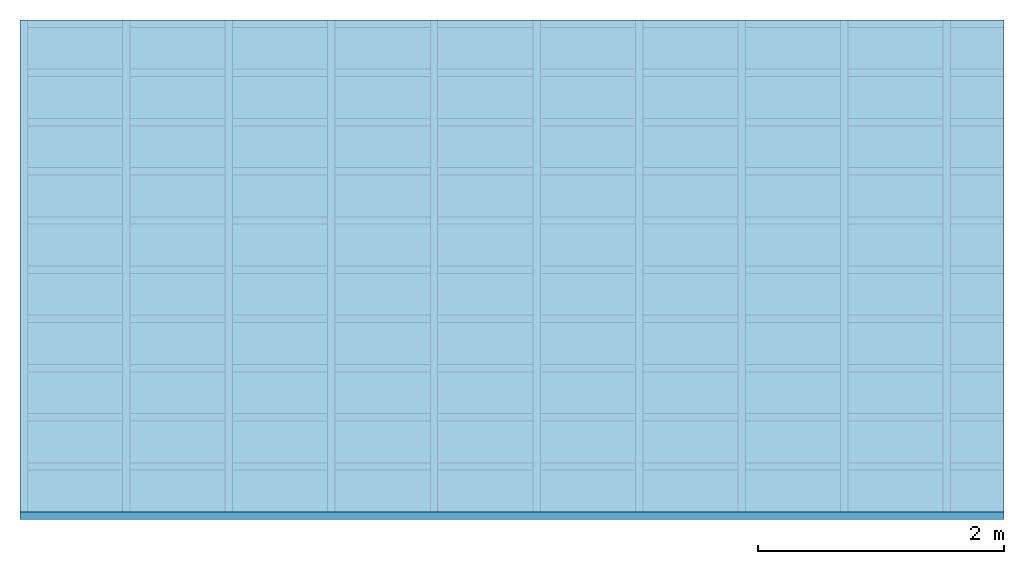
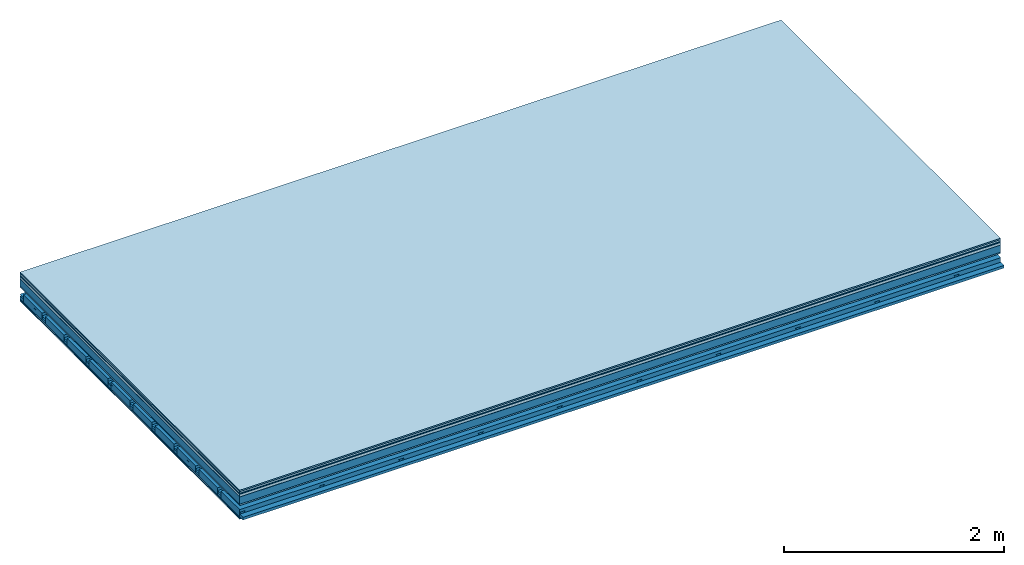
# One storey: 9 plates, 4 members, 1 element without a shape of its own.
"""IFC4 building model written with IfcOpenShell, lengths in metres."""

from ifc_helpers import new_model, si_unit, derived_unit, direction, frame, frame_2d, origin, origin_with_axes, place, context, project, spatial, polyline, rectangle, outline, extrude, material, layer, layer_set, type_object, element, aggregate, save


model = new_model("IFC4")

# Units and contexts
plan_context = context("Plan", 3, precision=1e-05, world=origin(), true_north=direction((0.0, 1.0)))
model_context = context("Model", 3, precision=1e-05, world=origin(), true_north=direction((0.0, 1.0)))
ifc_project = project(units=[si_unit("LENGTHUNIT", "METRE"), derived_unit("SOUNDPRESSUREUNIT", [(si_unit("PRESSUREUNIT", "PASCAL", prefix="MICRO"), 0)]), si_unit("ENERGYUNIT", "JOULE", prefix="MEGA"), si_unit("MASSUNIT", "GRAM", prefix="KILO"), derived_unit("THERMALTRANSMITTANCEUNIT", [(si_unit("POWERUNIT", "WATT"), 1), (si_unit("AREAUNIT", "SQUARE_METRE"), -1), (si_unit("THERMODYNAMICTEMPERATUREUNIT", "KELVIN"), -1)]), derived_unit("AREADENSITYUNIT", [(si_unit("MASSUNIT", "GRAM", prefix="KILO"), 1), (si_unit("AREAUNIT", "SQUARE_METRE"), -1)]), derived_unit("USERDEFINED", [(si_unit("ENERGYUNIT", "JOULE", prefix="MEGA"), 1), (si_unit("AREAUNIT", "SQUARE_METRE"), -1)])], contexts=[plan_context, model_context])

# Site, building, storey
site = spatial("IfcSite", under=ifc_project)
building_placement = place(None, origin())
building = spatial("IfcBuilding", under=site, at=building_placement)
storey_placement = place(building_placement, origin())
storey = spatial("IfcBuildingStorey", under=building, at=storey_placement)

# Slab, members, plates
ifc_material_1 = material(Category="11.013")
ifc_layer_1 = layer(ifc_material_1, 0.015, Name="Flooring")
ifc_material_2 = material(Category="03.007")
ifc_layer_2 = layer(ifc_material_2, 0.02, Name="On-material")
ifc_material_3 = material(Name="Wood fiber generic product", Category="10.009")
ifc_layer_3 = layer(ifc_material_3, 0.01, Name="Impact sound insulation")
ifc_material_4 = material(Name="with broken")
ifc_layer_4 = layer(ifc_material_4, 0.03, Name="on Supporting structure")
ifc_material_5 = material(Name="protection", Category="09.007")
ifc_layer_5 = layer(ifc_material_5, 0.0005, Name="Sub-floor")
ifc_material_6 = material(Name="no composite action")
ifc_layer_6 = layer(ifc_material_6, 0.0, Name="Bond")
ifc_layer_7 = layer(None, 0.08, Name="Supporting structure")
ifc_material_7 = material(Name="of the art")
ifc_layer_8 = layer(ifc_material_7, 0.0, Name="Bond")
ifc_layer_9 = layer(ifc_material_2, 0.015, Name="Lower layer 1")
ifc_layer_10 = layer(None, 0.095, Name="Coupling")
ifc_layer_11 = layer(None, 0.03, Name="Battens / profiles")
ifc_material_8 = material(Name="Plasterboard type A", Category="03.008")
ifc_layer_12 = layer(ifc_material_8, 0.0125, Name="Ceiling covering 1st layer")
ifc_layer_13 = layer(ifc_material_8, 0.0125, Name="Ceiling covering layer 2")
ifc_material_9 = material(Category="04.001")
ifc_layer_14 = layer(ifc_material_9, 0.003, Name="Surface / treatment")
ifc_layer_set = layer_set([ifc_layer_1, ifc_layer_2, ifc_layer_3, ifc_layer_4, ifc_layer_5, ifc_layer_6, ifc_layer_7, ifc_layer_8, ifc_layer_9, ifc_layer_10, ifc_layer_11, ifc_layer_12, ifc_layer_13, ifc_layer_14])
slab_type = type_object("IfcSlabType", Name="A2121", PredefinedType="NOTDEFINED", material=ifc_layer_set)
slab_placement = place(None, frame((0.0, 0.0, 0.0), z_axis=(0.0, 0.0, -1.0), x_axis=(1.0, 0.0, 0.0)))
slab = element("IfcSlab", 1, at=slab_placement, inside=storey, type_object=slab_type, material=ifc_layer_set, Name="Slab #1")
ifc_material_10 = material(Name="Solid timber panel")
member_1_placement = place(slab_placement, origin())
member_1 = element("IfcMember", 2, at=member_1_placement, material=ifc_material_10, Name="Supporting structure", context=plan_context, shape_type="SweptSolid", body=[
    extrude(rectangle(XDim=1.0, YDim=0.08, at=frame_2d((0.5, 0.04), x_axis=(1.0, 0.0))), frame((0.0, 4.0, 0.0755), z_axis=(0.0, -1.0, 0.0), x_axis=(1.0, 0.0, 0.0)), (0.0, 0.0, 1.0), 4.0),
    extrude(rectangle(XDim=1.0, YDim=0.08, at=frame_2d((0.5, 0.04), x_axis=(1.0, 0.0))), frame((1.0, 4.0, 0.0755), z_axis=(0.0, -1.0, 0.0), x_axis=(1.0, 0.0, 0.0)), (0.0, 0.0, 1.0), 4.0),
    extrude(rectangle(XDim=1.0, YDim=0.08, at=frame_2d((0.5, 0.04), x_axis=(1.0, 0.0))), frame((2.0, 4.0, 0.0755), z_axis=(0.0, -1.0, 0.0), x_axis=(1.0, 0.0, 0.0)), (0.0, 0.0, 1.0), 4.0),
    extrude(rectangle(XDim=1.0, YDim=0.08, at=frame_2d((0.5, 0.04), x_axis=(1.0, 0.0))), frame((3.0, 4.0, 0.0755), z_axis=(0.0, -1.0, 0.0), x_axis=(1.0, 0.0, 0.0)), (0.0, 0.0, 1.0), 4.0),
    extrude(rectangle(XDim=1.0, YDim=0.08, at=frame_2d((0.5, 0.04), x_axis=(1.0, 0.0))), frame((4.0, 4.0, 0.0755), z_axis=(0.0, -1.0, 0.0), x_axis=(1.0, 0.0, 0.0)), (0.0, 0.0, 1.0), 4.0),
    extrude(rectangle(XDim=1.0, YDim=0.08, at=frame_2d((0.5, 0.04), x_axis=(1.0, 0.0))), frame((5.0, 4.0, 0.0755), z_axis=(0.0, -1.0, 0.0), x_axis=(1.0, 0.0, 0.0)), (0.0, 0.0, 1.0), 4.0),
    extrude(rectangle(XDim=1.0, YDim=0.08, at=frame_2d((0.5, 0.04), x_axis=(1.0, 0.0))), frame((6.0, 4.0, 0.0755), z_axis=(0.0, -1.0, 0.0), x_axis=(1.0, 0.0, 0.0)), (0.0, 0.0, 1.0), 4.0),
    extrude(rectangle(XDim=1.0, YDim=0.08, at=frame_2d((0.5, 0.04), x_axis=(1.0, 0.0))), frame((7.0, 4.0, 0.0755), z_axis=(0.0, -1.0, 0.0), x_axis=(1.0, 0.0, 0.0)), (0.0, 0.0, 1.0), 4.0),
])
ifc_material_11 = material()
member_2_placement = place(slab_placement, origin())
member_2 = element("IfcMember", 3, at=member_2_placement, material=ifc_material_11, Name="Coupling", context=plan_context, shape_type="SweptSolid", body=[
    extrude(outline(polyline([(0.0, 0.0), (0.06, 0.0), (0.04, 0.02), (0.02, 0.02), (0.0, 0.0)])), frame((0.0, 4.0, 0.2455), z_axis=(0.0, -1.0, 0.0), x_axis=(1.0, 0.0, 0.0)), (0.0, 0.0, 1.0), 4.0),
    extrude(outline(polyline([(0.0, 0.0), (0.06, 0.0), (0.04, 0.02), (0.02, 0.02), (0.0, 0.0)])), frame((0.834, 4.0, 0.2455), z_axis=(0.0, -1.0, 0.0), x_axis=(1.0, 0.0, 0.0)), (0.0, 0.0, 1.0), 4.0),
    extrude(outline(polyline([(0.0, 0.0), (0.06, 0.0), (0.04, 0.02), (0.02, 0.02), (0.0, 0.0)])), frame((1.668, 4.0, 0.2455), z_axis=(0.0, -1.0, 0.0), x_axis=(1.0, 0.0, 0.0)), (0.0, 0.0, 1.0), 4.0),
    extrude(outline(polyline([(0.0, 0.0), (0.06, 0.0), (0.04, 0.02), (0.02, 0.02), (0.0, 0.0)])), frame((2.502, 4.0, 0.2455), z_axis=(0.0, -1.0, 0.0), x_axis=(1.0, 0.0, 0.0)), (0.0, 0.0, 1.0), 4.0),
    extrude(outline(polyline([(0.0, 0.0), (0.06, 0.0), (0.04, 0.02), (0.02, 0.02), (0.0, 0.0)])), frame((3.336, 4.0, 0.2455), z_axis=(0.0, -1.0, 0.0), x_axis=(1.0, 0.0, 0.0)), (0.0, 0.0, 1.0), 4.0),
    extrude(outline(polyline([(0.0, 0.0), (0.06, 0.0), (0.04, 0.02), (0.02, 0.02), (0.0, 0.0)])), frame((4.17, 4.0, 0.2455), z_axis=(0.0, -1.0, 0.0), x_axis=(1.0, 0.0, 0.0)), (0.0, 0.0, 1.0), 4.0),
    extrude(outline(polyline([(0.0, 0.0), (0.06, 0.0), (0.04, 0.02), (0.02, 0.02), (0.0, 0.0)])), frame((5.004, 4.0, 0.2455), z_axis=(0.0, -1.0, 0.0), x_axis=(1.0, 0.0, 0.0)), (0.0, 0.0, 1.0), 4.0),
    extrude(outline(polyline([(0.0, 0.0), (0.06, 0.0), (0.04, 0.02), (0.02, 0.02), (0.0, 0.0)])), frame((5.838, 4.0, 0.2455), z_axis=(0.0, -1.0, 0.0), x_axis=(1.0, 0.0, 0.0)), (0.0, 0.0, 1.0), 4.0),
    extrude(outline(polyline([(0.0, 0.0), (0.06, 0.0), (0.04, 0.02), (0.02, 0.02), (0.0, 0.0)])), frame((6.672, 4.0, 0.2455), z_axis=(0.0, -1.0, 0.0), x_axis=(1.0, 0.0, 0.0)), (0.0, 0.0, 1.0), 4.0),
    extrude(outline(polyline([(0.0, 0.0), (0.06, 0.0), (0.04, 0.02), (0.02, 0.02), (0.0, 0.0)])), frame((7.506, 4.0, 0.2455), z_axis=(0.0, -1.0, 0.0), x_axis=(1.0, 0.0, 0.0)), (0.0, 0.0, 1.0), 4.0),
])
member_3_placement = place(slab_placement, origin())
member_3 = element("IfcMember", 4, at=member_3_placement, material=ifc_material_11, Name="Battens / profiles", context=plan_context, shape_type="SweptSolid", body=[
    extrude(rectangle(XDim=0.06, YDim=0.03, at=frame_2d((0.03, 0.015), x_axis=(1.0, 0.0))), frame((0.0, 0.0, 0.2655), z_axis=(1.0, 0.0, 0.0), x_axis=(0.0, 1.0, 0.0)), (0.0, 0.0, 1.0), 8.0),
    extrude(rectangle(XDim=0.06, YDim=0.03, at=frame_2d((0.03, 0.015), x_axis=(1.0, 0.0))), frame((0.0, 0.4, 0.2655), z_axis=(1.0, 0.0, 0.0), x_axis=(0.0, 1.0, 0.0)), (0.0, 0.0, 1.0), 8.0),
    extrude(rectangle(XDim=0.06, YDim=0.03, at=frame_2d((0.03, 0.015), x_axis=(1.0, 0.0))), frame((0.0, 0.8, 0.2655), z_axis=(1.0, 0.0, 0.0), x_axis=(0.0, 1.0, 0.0)), (0.0, 0.0, 1.0), 8.0),
    extrude(rectangle(XDim=0.06, YDim=0.03, at=frame_2d((0.03, 0.015), x_axis=(1.0, 0.0))), frame((0.0, 1.2, 0.2655), z_axis=(1.0, 0.0, 0.0), x_axis=(0.0, 1.0, 0.0)), (0.0, 0.0, 1.0), 8.0),
    extrude(rectangle(XDim=0.06, YDim=0.03, at=frame_2d((0.03, 0.015), x_axis=(1.0, 0.0))), frame((0.0, 1.6, 0.2655), z_axis=(1.0, 0.0, 0.0), x_axis=(0.0, 1.0, 0.0)), (0.0, 0.0, 1.0), 8.0),
    extrude(rectangle(XDim=0.06, YDim=0.03, at=frame_2d((0.03, 0.015), x_axis=(1.0, 0.0))), frame((0.0, 2.0, 0.2655), z_axis=(1.0, 0.0, 0.0), x_axis=(0.0, 1.0, 0.0)), (0.0, 0.0, 1.0), 8.0),
    extrude(rectangle(XDim=0.06, YDim=0.03, at=frame_2d((0.03, 0.015), x_axis=(1.0, 0.0))), frame((0.0, 2.4, 0.2655), z_axis=(1.0, 0.0, 0.0), x_axis=(0.0, 1.0, 0.0)), (0.0, 0.0, 1.0), 8.0),
    extrude(rectangle(XDim=0.06, YDim=0.03, at=frame_2d((0.03, 0.015), x_axis=(1.0, 0.0))), frame((0.0, 2.8, 0.2655), z_axis=(1.0, 0.0, 0.0), x_axis=(0.0, 1.0, 0.0)), (0.0, 0.0, 1.0), 8.0),
    extrude(rectangle(XDim=0.06, YDim=0.03, at=frame_2d((0.03, 0.015), x_axis=(1.0, 0.0))), frame((0.0, 3.2, 0.2655), z_axis=(1.0, 0.0, 0.0), x_axis=(0.0, 1.0, 0.0)), (0.0, 0.0, 1.0), 8.0),
    extrude(rectangle(XDim=0.06, YDim=0.03, at=frame_2d((0.03, 0.015), x_axis=(1.0, 0.0))), frame((0.0, 3.6, 0.2655), z_axis=(1.0, 0.0, 0.0), x_axis=(0.0, 1.0, 0.0)), (0.0, 0.0, 1.0), 8.0),
    extrude(rectangle(XDim=0.06, YDim=0.03, at=frame_2d((0.03, 0.015), x_axis=(1.0, 0.0))), frame((0.0, 4.0, 0.2655), z_axis=(1.0, 0.0, 0.0), x_axis=(0.0, 1.0, 0.0)), (0.0, 0.0, 1.0), 8.0),
])
ifc_material_12 = material()
member_4_placement = place(slab_placement, origin())
member_4 = element("IfcMember", 5, at=member_4_placement, material=ifc_material_12, Name="Cavity", context=plan_context, shape_type="SweptSolid", body=[
    extrude(rectangle(XDim=0.34, YDim=0.08, at=frame_2d((0.17, 0.04), x_axis=(1.0, 0.0))), frame((0.0, 0.06, 0.2155), z_axis=(1.0, 0.0, 0.0), x_axis=(0.0, 1.0, 0.0)), (0.0, 0.0, 1.0), 8.0),
    extrude(rectangle(XDim=0.34, YDim=0.08, at=frame_2d((0.17, 0.04), x_axis=(1.0, 0.0))), frame((0.0, 0.46, 0.2155), z_axis=(1.0, 0.0, 0.0), x_axis=(0.0, 1.0, 0.0)), (0.0, 0.0, 1.0), 8.0),
    extrude(rectangle(XDim=0.34, YDim=0.08, at=frame_2d((0.17, 0.04), x_axis=(1.0, 0.0))), frame((0.0, 0.86, 0.2155), z_axis=(1.0, 0.0, 0.0), x_axis=(0.0, 1.0, 0.0)), (0.0, 0.0, 1.0), 8.0),
    extrude(rectangle(XDim=0.34, YDim=0.08, at=frame_2d((0.17, 0.04), x_axis=(1.0, 0.0))), frame((0.0, 1.26, 0.2155), z_axis=(1.0, 0.0, 0.0), x_axis=(0.0, 1.0, 0.0)), (0.0, 0.0, 1.0), 8.0),
    extrude(rectangle(XDim=0.34, YDim=0.08, at=frame_2d((0.17, 0.04), x_axis=(1.0, 0.0))), frame((0.0, 1.66, 0.2155), z_axis=(1.0, 0.0, 0.0), x_axis=(0.0, 1.0, 0.0)), (0.0, 0.0, 1.0), 8.0),
    extrude(rectangle(XDim=0.34, YDim=0.08, at=frame_2d((0.17, 0.04), x_axis=(1.0, 0.0))), frame((0.0, 2.06, 0.2155), z_axis=(1.0, 0.0, 0.0), x_axis=(0.0, 1.0, 0.0)), (0.0, 0.0, 1.0), 8.0),
    extrude(rectangle(XDim=0.34, YDim=0.08, at=frame_2d((0.17, 0.04), x_axis=(1.0, 0.0))), frame((0.0, 2.46, 0.2155), z_axis=(1.0, 0.0, 0.0), x_axis=(0.0, 1.0, 0.0)), (0.0, 0.0, 1.0), 8.0),
    extrude(rectangle(XDim=0.34, YDim=0.08, at=frame_2d((0.17, 0.04), x_axis=(1.0, 0.0))), frame((0.0, 2.86, 0.2155), z_axis=(1.0, 0.0, 0.0), x_axis=(0.0, 1.0, 0.0)), (0.0, 0.0, 1.0), 8.0),
    extrude(rectangle(XDim=0.34, YDim=0.08, at=frame_2d((0.17, 0.04), x_axis=(1.0, 0.0))), frame((0.0, 3.26, 0.2155), z_axis=(1.0, 0.0, 0.0), x_axis=(0.0, 1.0, 0.0)), (0.0, 0.0, 1.0), 8.0),
    extrude(rectangle(XDim=0.34, YDim=0.08, at=frame_2d((0.17, 0.04), x_axis=(1.0, 0.0))), frame((0.0, 3.66, 0.2155), z_axis=(1.0, 0.0, 0.0), x_axis=(0.0, 1.0, 0.0)), (0.0, 0.0, 1.0), 8.0),
])
plate_1_placement = place(slab_placement, origin())
plate_1 = element("IfcPlate", 6, at=plate_1_placement, material=ifc_material_1, Name="Flooring", context=plan_context, shape_type="SweptSolid", body=[
    extrude(rectangle(XDim=8.0, YDim=4.0, at=frame_2d((4.0, 2.0), x_axis=(1.0, 0.0))), origin_with_axes(), (0.0, 0.0, 1.0), 0.015),
])
plate_2_placement = place(slab_placement, origin())
plate_2 = element("IfcPlate", 7, at=plate_2_placement, material=ifc_material_2, Name="On-material", context=plan_context, shape_type="SweptSolid", body=[
    extrude(rectangle(XDim=8.0, YDim=4.0, at=frame_2d((4.0, 2.0), x_axis=(1.0, 0.0))), frame((0.0, 0.0, 0.015), z_axis=(0.0, 0.0, 1.0), x_axis=(1.0, 0.0, 0.0)), (0.0, 0.0, 1.0), 0.02),
])
plate_3_placement = place(slab_placement, origin())
plate_3 = element("IfcPlate", 8, at=plate_3_placement, material=ifc_material_3, Name="Impact sound insulation", context=plan_context, shape_type="SweptSolid", body=[
    extrude(rectangle(XDim=8.0, YDim=4.0, at=frame_2d((4.0, 2.0), x_axis=(1.0, 0.0))), frame((0.0, 0.0, 0.035), z_axis=(0.0, 0.0, 1.0), x_axis=(1.0, 0.0, 0.0)), (0.0, 0.0, 1.0), 0.01),
])
plate_4_placement = place(slab_placement, origin())
plate_4 = element("IfcPlate", 9, at=plate_4_placement, material=ifc_material_4, Name="on Supporting structure", context=plan_context, shape_type="SweptSolid", body=[
    extrude(rectangle(XDim=8.0, YDim=4.0, at=frame_2d((4.0, 2.0), x_axis=(1.0, 0.0))), frame((0.0, 0.0, 0.045), z_axis=(0.0, 0.0, 1.0), x_axis=(1.0, 0.0, 0.0)), (0.0, 0.0, 1.0), 0.03),
])
plate_5_placement = place(slab_placement, origin())
plate_5 = element("IfcPlate", 10, at=plate_5_placement, material=ifc_material_5, Name="Sub-floor", context=plan_context, shape_type="SweptSolid", body=[
    extrude(rectangle(XDim=8.0, YDim=4.0, at=frame_2d((4.0, 2.0), x_axis=(1.0, 0.0))), frame((0.0, 0.0, 0.075), z_axis=(0.0, 0.0, 1.0), x_axis=(1.0, 0.0, 0.0)), (0.0, 0.0, 1.0), 0.0005),
])
plate_6_placement = place(slab_placement, origin())
plate_6 = element("IfcPlate", 11, at=plate_6_placement, material=ifc_material_2, Name="Lower layer 1", context=plan_context, shape_type="SweptSolid", body=[
    extrude(rectangle(XDim=8.0, YDim=4.0, at=frame_2d((4.0, 2.0), x_axis=(1.0, 0.0))), frame((0.0, 0.0, 0.1555), z_axis=(0.0, 0.0, 1.0), x_axis=(1.0, 0.0, 0.0)), (0.0, 0.0, 1.0), 0.015),
])
plate_7_placement = place(slab_placement, origin())
plate_7 = element("IfcPlate", 12, at=plate_7_placement, material=ifc_material_8, Name="Ceiling covering 1st layer", context=plan_context, shape_type="SweptSolid", body=[
    extrude(rectangle(XDim=8.0, YDim=4.0, at=frame_2d((4.0, 2.0), x_axis=(1.0, 0.0))), frame((0.0, 0.0, 0.2955), z_axis=(0.0, 0.0, 1.0), x_axis=(1.0, 0.0, 0.0)), (0.0, 0.0, 1.0), 0.0125),
])
plate_8_placement = place(slab_placement, origin())
plate_8 = element("IfcPlate", 13, at=plate_8_placement, material=ifc_material_8, Name="Ceiling covering layer 2", context=plan_context, shape_type="SweptSolid", body=[
    extrude(rectangle(XDim=8.0, YDim=4.0, at=frame_2d((4.0, 2.0), x_axis=(1.0, 0.0))), frame((0.0, 0.0, 0.308), z_axis=(0.0, 0.0, 1.0), x_axis=(1.0, 0.0, 0.0)), (0.0, 0.0, 1.0), 0.0125),
])
plate_9_placement = place(slab_placement, origin())
plate_9 = element("IfcPlate", 14, at=plate_9_placement, material=ifc_material_9, Name="Surface / treatment", context=plan_context, shape_type="SweptSolid", body=[
    extrude(rectangle(XDim=8.0, YDim=4.0, at=frame_2d((4.0, 2.0), x_axis=(1.0, 0.0))), frame((0.0, 0.0, 0.3205), z_axis=(0.0, 0.0, 1.0), x_axis=(1.0, 0.0, 0.0)), (0.0, 0.0, 1.0), 0.003),
])
aggregate(slab, [plate_1, plate_2, plate_3, plate_4, plate_5, member_1, plate_6, member_2, member_3, member_4, plate_7, plate_8, plate_9])

save(model, "model.ifc")
